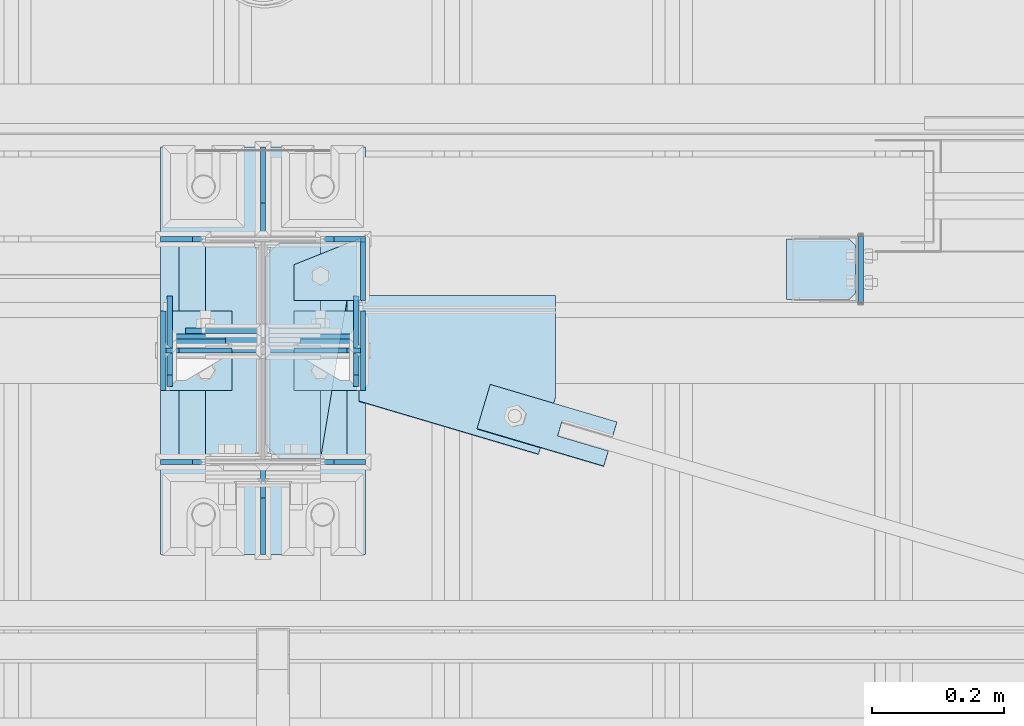
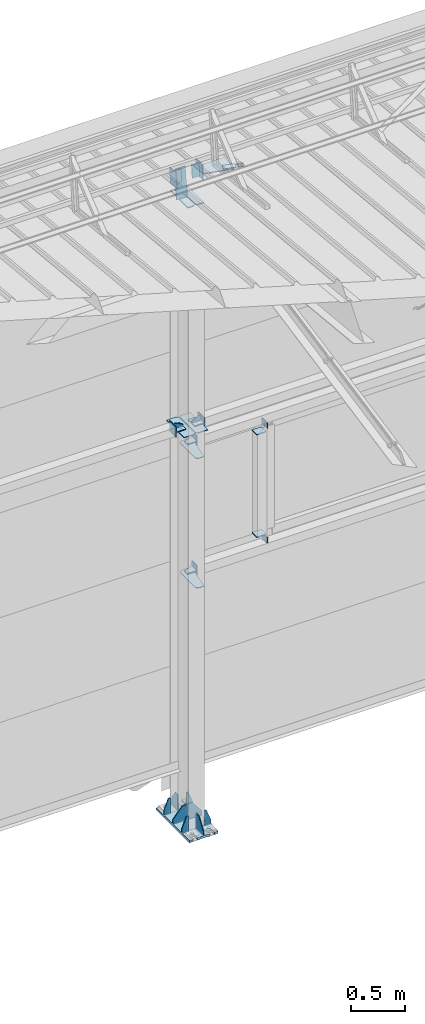
# One storey, part 163 of 709: 36 plates, 5 openings, 9 elements without a shape of their own.
"""IFC4 building model written with IfcOpenShell, lengths in millimetres."""

import ifcopenshell
import ifcopenshell.guid

model = None  # the IFC model being written
_history = None  # IfcOwnerHistory: only IFC2X3 demands one
_inside = {}  # id of a spatial element -> (the spatial element, [elements in it])
_under = {}  # id of a project, library or spatial element -> (it, [spatial elements below it])
_declared = {}  # id of a project -> (the project, [libraries it declares])
_typed = {}  # id of a type object -> (the type object, [elements of that type])
_made_of = {}  # id of a material, layer set ... -> (it, [elements and type objects made of it])


def new_model(schema):
    """Start an empty IFC model of exactly this schema.

    Asked for "IFC4X3", IfcOpenShell would pick the latest addendum, in which some entities
    have other attributes; the version numbers below select the first issue.
    IFC2X3 requires an IfcOwnerHistory on every rooted entity: one is made here for all.
    """
    global model, _history
    if schema == "IFC4X3":
        model = ifcopenshell.file(schema_version=(4, 3, 0, 0))
    else:
        model = ifcopenshell.file(schema=schema)
    _inside.clear()
    _under.clear()
    _declared.clear()
    _typed.clear()
    _made_of.clear()
    _history = None
    if model.schema == "IFC2X3":
        org = make("IfcOrganization", Name="unknown")
        user = make(
            "IfcPersonAndOrganization",
            ThePerson=make("IfcPerson", FamilyName="unknown"),
            TheOrganization=org,
        )
        app = make(
            "IfcApplication",
            ApplicationDeveloper=org,
            Version="unknown",
            ApplicationFullName="unknown",
            ApplicationIdentifier="unknown",
        )
        _history = make(
            "IfcOwnerHistory",
            OwningUser=user,
            OwningApplication=app,
            ChangeAction="ADDED",
            CreationDate=0,
        )
    return model


def make(cls, **values):
    """One entity of the class cls with the attributes given. An attribute that is None is left unset."""
    return model.create_entity(
        cls, **{name: value for name, value in values.items() if value is not None}
    )


def rooted(cls, **values):
    """An entity with a GlobalId (a new one), such as an element, a storey or a relation."""
    return make(cls, GlobalId=ifcopenshell.guid.new(), OwnerHistory=_history, **values)


def si_unit(unit_type, name, prefix=None):
    """IfcSIUnit, for example si_unit("LENGTHUNIT", "METRE", prefix="MILLI")."""
    return make("IfcSIUnit", UnitType=unit_type, Prefix=prefix, Name=name)


def assignment(units):
    """IfcUnitAssignment: the units of a project."""
    return None if units is None else make("IfcUnitAssignment", Units=units)


def point(xyz):
    """IfcCartesianPoint."""
    return None if xyz is None else make("IfcCartesianPoint", Coordinates=xyz)


def direction(xyz):
    """IfcDirection."""
    return None if xyz is None else make("IfcDirection", DirectionRatios=xyz)


def frame(location, z_axis=None, x_axis=None):
    """IfcAxis2Placement3D, a coordinate frame: its origin and axes. An axis left out is left unset."""
    return make(
        "IfcAxis2Placement3D",
        Location=point(location),
        Axis=direction(z_axis),
        RefDirection=direction(x_axis),
    )


def origin_with_axes():
    """The frame at (0, 0, 0) with the z axis (0, 0, 1) and the x axis (1, 0, 0) written out."""
    return frame((0.0, 0.0, 0.0), z_axis=(0.0, 0.0, 1.0), x_axis=(1.0, 0.0, 0.0))


def place(relative_to, where):
    """IfcLocalPlacement: puts the frame where relative to a parent placement (None: the world)."""
    return make(
        "IfcLocalPlacement", PlacementRelTo=relative_to, RelativePlacement=where
    )


def context(
    kind, dimensions, precision=None, world=None, true_north=None, identifier=None
):
    """IfcGeometricRepresentationContext, for example the 3D "Model" context."""
    return make(
        "IfcGeometricRepresentationContext",
        ContextIdentifier=identifier,
        ContextType=kind,
        CoordinateSpaceDimension=dimensions,
        Precision=precision,
        WorldCoordinateSystem=world,
        TrueNorth=true_north,
    )


def subcontext(parent, identifier, kind, view, scale=None):
    """IfcGeometricRepresentationSubContext, for example "Body" below "Model"."""
    return make(
        "IfcGeometricRepresentationSubContext",
        ContextIdentifier=identifier,
        ContextType=kind,
        ParentContext=parent,
        TargetScale=scale,
        TargetView=view,
    )


def project(units=None, contexts=None):
    """IfcProject with its units and contexts."""
    return rooted(
        "IfcProject",
        Name="project",
        RepresentationContexts=contexts,
        UnitsInContext=assignment(units),
    )


def spatial(cls, under=None, at=None, **own):
    """A site, building, storey or space (cls), placed at a placement, below another one or the project."""
    s = rooted(cls, ObjectPlacement=at, **own)
    if under is not None:
        _under.setdefault(under.id(), (under, []))[1].append(s)
    return s


def point_list(points):
    """IfcCartesianPointList2D or 3D."""
    cls = (
        "IfcCartesianPointList2D" if len(points[0]) == 2 else "IfcCartesianPointList3D"
    )
    return make(cls, CoordList=points)


def line(*indices):
    """IfcLineIndex: a straight run through numbered points of an indexed curve."""
    return model.create_entity("IfcLineIndex", indices)


def arc(*indices):
    """IfcArcIndex: an arc through three numbered points of an indexed curve."""
    return model.create_entity("IfcArcIndex", indices)


def indexed_curve(points, segments=None, self_intersect=None):
    """IfcIndexedPolyCurve: lines and arcs through numbered points (the first is 1)."""
    return make(
        "IfcIndexedPolyCurve",
        Points=point_list(points),
        Segments=segments,
        SelfIntersect=self_intersect,
    )


def outline(outer, holes=None, kind="AREA"):
    """IfcArbitraryClosedProfileDef: a profile drawn as a closed curve; with holes, ...WithVoids."""
    if holes is None:
        return make("IfcArbitraryClosedProfileDef", ProfileType=kind, OuterCurve=outer)
    return make(
        "IfcArbitraryProfileDefWithVoids",
        ProfileType=kind,
        OuterCurve=outer,
        InnerCurves=holes,
    )


def extrude(swept, where, along, depth):
    """IfcExtrudedAreaSolid: the profile swept, set in the frame where, extruded along a direction by depth."""
    return make(
        "IfcExtrudedAreaSolid",
        SweptArea=swept,
        Position=where,
        ExtrudedDirection=direction(along),
        Depth=depth,
    )


def shape(context_of_items, identifier, shape_type, items):
    """IfcShapeRepresentation: the items that make up one representation, for example the "Body"."""
    return make(
        "IfcShapeRepresentation",
        ContextOfItems=context_of_items,
        RepresentationIdentifier=identifier,
        RepresentationType=shape_type,
        Items=items,
    )


def material(Name=None, Category=None):
    """IfcMaterial."""
    return make("IfcMaterial", Name=Name, Category=Category)


def made_of(thing, what):
    """Note that an element or type object is made of a material, layer set ...; save() writes the relation."""
    if what is not None:
        _made_of.setdefault(what.id(), (what, []))[1].append(thing)
    return thing


def element(
    cls,
    number,
    at=None,
    inside=None,
    cuts=None,
    type_object=None,
    material=None,
    context=None,
    identifier="Body",
    shape_type=None,
    held_by="IfcProductDefinitionShape",
    body=None,
    shapes=None,
    **own,
):
    """One element of the class cls, such as IfcWall. Its Tag is "e" and its number.

    at: its placement. inside: the storey or other place that contains it. cuts: it is an
    opening in that element (IfcRelVoidsElement). A single representation is given by context,
    identifier, shape_type and body (its items); several are given by shapes. held_by: the class
    of the entity that holds the representations. save() writes the other relations.
    """
    e = rooted(cls, Tag="e%d" % number, ObjectPlacement=at, **own)
    if body is not None:
        shapes = [shape(context, identifier, shape_type, body)]
    if shapes is not None:
        e.Representation = make(held_by, Representations=shapes)
    if inside is not None:
        _inside.setdefault(inside.id(), (inside, []))[1].append(e)
    if cuts is not None:
        rooted(
            "IfcRelVoidsElement", RelatingBuildingElement=cuts, RelatedOpeningElement=e
        )
    if type_object is not None:
        _typed.setdefault(type_object.id(), (type_object, []))[1].append(e)
    return made_of(e, material)


def aggregate(whole, parts):
    """IfcRelAggregates: a whole, such as a stair, and the parts it consists of."""
    return rooted("IfcRelAggregates", RelatingObject=whole, RelatedObjects=parts)


def save(model, path):
    """Write the relations noted so far, then the file.

    IfcRelAggregates (storeys below a building ...), IfcRelContainedInSpatialStructure (elements
    in a storey), IfcRelDefinesByType, IfcRelAssociatesMaterial and IfcRelDeclares: one each for
    every whole, place, type object, material and project.
    """
    for whole, parts in _under.values():
        aggregate(whole, parts)
    for where, things in _inside.values():
        rooted(
            "IfcRelContainedInSpatialStructure",
            RelatedElements=things,
            RelatingStructure=where,
        )
    for kind, things in _typed.values():
        rooted("IfcRelDefinesByType", RelatedObjects=things, RelatingType=kind)
    for what, things in _made_of.values():
        rooted("IfcRelAssociatesMaterial", RelatedObjects=things, RelatingMaterial=what)
    for by, libraries in _declared.values():
        rooted("IfcRelDeclares", RelatingContext=by, RelatedDefinitions=libraries)
    model.write(path)


model = new_model("IFC4")

# Units and contexts
model_context = context("Model", 3, precision=0.2, world=origin_with_axes(), true_north=direction((0.0, 1.0)))
body_context = subcontext(model_context, "Body", "Model", "MODEL_VIEW")
ifc_project = project(units=[si_unit("LENGTHUNIT", "METRE", prefix="MILLI"), si_unit("AREAUNIT", "SQUARE_METRE"), si_unit("VOLUMEUNIT", "CUBIC_METRE"), si_unit("MASSUNIT", "GRAM", prefix="KILO"), si_unit("TIMEUNIT", "SECOND"), si_unit("PLANEANGLEUNIT", "RADIAN"), si_unit("SOLIDANGLEUNIT", "STERADIAN"), si_unit("THERMODYNAMICTEMPERATUREUNIT", "DEGREE_CELSIUS"), si_unit("LUMINOUSINTENSITYUNIT", "LUMEN")], contexts=[model_context])

# Site, building, storey
site_placement = place(None, origin_with_axes())
site = spatial("IfcSite", under=ifc_project, at=site_placement, CompositionType="ELEMENT")
building_placement = place(site_placement, origin_with_axes())
building = spatial("IfcBuilding", under=site, at=building_placement, Name="Undefined", CompositionType="ELEMENT")
storey_placement = place(building_placement, origin_with_axes())
storey = spatial("IfcBuildingStorey", under=building, at=storey_placement, Name="Undefined", CompositionType="ELEMENT", Elevation=0.0)

# Assembly, plates, voiding features
assembly_1_placement = place(storey_placement, frame((40000.0, 21827.0, -200.0), z_axis=(-1.0, 0.0, 0.0), x_axis=(0.0, 0.0, 1.0)))
assembly_1 = element("IfcElementAssembly", 1, at=assembly_1_placement, inside=storey)
ifc_material = material(Name="C355-6", Category="STEEL")
plate_1_placement = place(assembly_1_placement, frame((7434.21546, 30.02526, 3.0), z_axis=(0.099503719, -0.9950371902, 0.0), x_axis=(0.0, 0.0, 1.0)))
plate_1 = element("IfcPlate", 2, at=plate_1_placement, material=ifc_material, ObjectType="595", context=body_context, shape_type="SolidModel", body=[
    extrude(outline(indexed_curve([(0.0, 0.0), (114.0, 0.0), (114.0, 332.53554), (0.0, 332.53554)], segments=[line(1, 2, 3, 4, 1)])), frame((0.0, 0.0, 4.0), z_axis=(0.0, 0.0, 1.0), x_axis=(1.0, 0.0, 0.0)), (0.0, 0.0, -1.0), 8.0),
])
plate_2_placement = place(assembly_1_placement, frame((4502.0, 163.0, 127.0), z_axis=(-1.0, 0.0, 0.0), x_axis=(0.0, 0.0, -1.0)))
plate_2 = element("IfcPlate", 3, at=plate_2_placement, material=ifc_material, ObjectType="547", context=body_context, shape_type="SolidModel", body=[
    extrude(outline(indexed_curve([(0.0, 0.0), (108.0, 0.0), (123.0, 15.0), (123.0, 311.0), (108.0, 326.0), (0.0, 326.0)], segments=[line(1, 2, 3, 4, 5, 6, 1)])), frame((0.0, 0.0, 4.0), z_axis=(0.0, 0.0, 1.0), x_axis=(1.0, 0.0, 0.0)), (0.0, 0.0, -1.0), 8.0),
])
plate_3_placement = place(assembly_1_placement, frame((4502.0, -163.0, -127.0), z_axis=(-1.0, 0.0, 0.0), x_axis=(0.0, 0.0, 1.0)))
plate_3 = element("IfcPlate", 4, at=plate_3_placement, material=ifc_material, ObjectType="547", context=body_context, shape_type="SolidModel", body=[
    extrude(outline(indexed_curve([(0.0, 0.0), (108.0, 0.0), (123.0, 15.0), (123.0, 311.0), (108.0, 326.0), (0.0, 326.0)], segments=[line(1, 2, 3, 4, 5, 6, 1)])), frame((0.0, 0.0, 4.0), z_axis=(0.0, 0.0, 1.0), x_axis=(1.0, 0.0, 0.0)), (0.0, 0.0, -1.0), 8.0),
])
plate_4_placement = place(assembly_1_placement, frame((4212.0, -163.0, -4.0), z_axis=(1.0, 0.0, 0.0), x_axis=(0.0, 0.0, -1.0)))
plate_4 = element("IfcPlate", 5, at=plate_4_placement, material=ifc_material, ObjectType="543", context=body_context, shape_type="SolidModel", body=[
    extrude(outline(indexed_curve([(0.0, 20.0), (20.0, 0.0), (83.0, 0.0), (123.0, 240.0), (123.0, 326.0), (20.0, 326.0), (0.0, 306.0)], segments=[line(1, 2, 3, 4, 5, 6, 7, 1)])), frame((0.0, 0.0, 4.0), z_axis=(0.0, 0.0, 1.0), x_axis=(1.0, 0.0, 0.0)), (0.0, 0.0, -1.0), 8.0),
])
plate_5_placement = place(assembly_1_placement, frame((2742.0, -163.0, -4.0), z_axis=(1.0, 0.0, 0.0), x_axis=(0.0, 0.0, -1.0)))
plate_5 = element("IfcPlate", 6, at=plate_5_placement, material=ifc_material, ObjectType="543", context=body_context, shape_type="SolidModel", body=[
    extrude(outline(indexed_curve([(0.0, 20.0), (20.0, 0.0), (83.0, 0.0), (123.0, 240.0), (123.0, 326.0), (20.0, 326.0), (0.0, 306.0)], segments=[line(1, 2, 3, 4, 5, 6, 7, 1)])), frame((0.0, 0.0, 4.0), z_axis=(0.0, 0.0, 1.0), x_axis=(1.0, 0.0, 0.0)), (0.0, 0.0, -1.0), 8.0),
])
plate_6_placement = place(assembly_1_placement, frame((7097.93718, 163.0, 87.0), z_axis=(-1.0, 0.0, 0.0), x_axis=(0.0, 0.0, -1.0)))
plate_6 = element("IfcPlate", 7, at=plate_6_placement, material=ifc_material, ObjectType="461", context=body_context, shape_type="SolidModel", body=[
    extrude(outline(indexed_curve([(0.0, 0.0), (68.0, 0.0), (83.0, 15.0), (83.0, 311.0), (68.0, 326.0), (0.0, 326.0)], segments=[line(1, 2, 3, 4, 5, 6, 1)])), frame((0.0, 0.0, 4.0), z_axis=(0.0, 0.0, 1.0), x_axis=(1.0, 0.0, 0.0)), (0.0, 0.0, -1.0), 8.0),
])
plate_7_placement = place(assembly_1_placement, frame((7097.93718, -163.0, -87.0), z_axis=(-1.0, 0.0, 0.0), x_axis=(0.0, 0.0, 1.0)))
plate_7 = element("IfcPlate", 8, at=plate_7_placement, material=ifc_material, ObjectType="461", context=body_context, shape_type="SolidModel", body=[
    extrude(outline(indexed_curve([(0.0, 0.0), (68.0, 0.0), (83.0, 15.0), (83.0, 311.0), (68.0, 326.0), (0.0, 326.0)], segments=[line(1, 2, 3, 4, 5, 6, 1)])), frame((0.0, 0.0, 4.0), z_axis=(0.0, 0.0, 1.0), x_axis=(1.0, 0.0, 0.0)), (0.0, 0.0, -1.0), 8.0),
])
plate_8_placement = place(assembly_1_placement, frame((25.0, 173.0, 0.0), z_axis=(0.0, 0.0, -1.0), x_axis=(0.0, 1.0, 0.0)))
plate_8 = element("IfcPlate", 9, at=plate_8_placement, material=ifc_material, ObjectType="418", context=body_context, shape_type="SolidModel", body=[
    extrude(outline(indexed_curve([(0.0, 0.0), (135.0, 0.0), (135.0, 50.0), (50.0, 175.0), (0.0, 175.0)], segments=[line(1, 2, 3, 4, 5, 1)])), frame((0.0, 0.0, 4.0), z_axis=(0.0, 0.0, 1.0), x_axis=(1.0, 0.0, 0.0)), (0.0, 0.0, -1.0), 8.0),
])
plate_9_placement = place(assembly_1_placement, frame((25.0, 0.0, 3.0), z_axis=(0.0, 1.0, 0.0), x_axis=(0.0, 0.0, 1.0)))
plate_9 = element("IfcPlate", 10, at=plate_9_placement, material=ifc_material, ObjectType="417", context=body_context, shape_type="SolidModel", body=[
    extrude(outline(indexed_curve([(0.0, 0.0), (152.0, 0.0), (152.0, 50.0), (50.0, 175.0), (0.0, 175.0)], segments=[line(1, 2, 3, 4, 5, 1)])), frame((0.0, 0.0, 4.0), z_axis=(0.0, 0.0, 1.0), x_axis=(1.0, 0.0, 0.0)), (0.0, 0.0, -1.0), 8.0),
])
plate_10_placement = place(assembly_1_placement, frame((25.0, -168.5, 87.0), z_axis=(0.0, 1.0, 0.0), x_axis=(0.0, 0.0, 1.0)))
plate_10 = element("IfcPlate", 11, at=plate_10_placement, material=ifc_material, ObjectType="419", context=body_context, shape_type="SolidModel", body=[
    extrude(outline(indexed_curve([(0.0, 0.0), (68.0, 0.0), (68.0, 50.0), (20.0, 175.0), (0.0, 175.0)], segments=[line(1, 2, 3, 4, 5, 1)])), frame((0.0, 0.0, 4.0), z_axis=(0.0, 0.0, 1.0), x_axis=(1.0, 0.0, 0.0)), (0.0, 0.0, -1.0), 8.0),
])
plate_11_placement = place(assembly_1_placement, frame((25.0, 168.5, -87.0), z_axis=(0.0, -1.0, 0.0), x_axis=(0.0, 0.0, -1.0)))
plate_11 = element("IfcPlate", 12, at=plate_11_placement, material=ifc_material, ObjectType="419", context=body_context, shape_type="SolidModel", body=[
    extrude(outline(indexed_curve([(0.0, 0.0), (68.0, 0.0), (68.0, 50.0), (20.0, 175.0), (0.0, 175.0)], segments=[line(1, 2, 3, 4, 5, 1)])), frame((0.0, 0.0, 4.0), z_axis=(0.0, 0.0, 1.0), x_axis=(1.0, 0.0, 0.0)), (0.0, 0.0, -1.0), 8.0),
])
plate_12_placement = place(assembly_1_placement, frame((25.0, 168.5, 87.0), z_axis=(0.0, 1.0, 0.0), x_axis=(0.0, 0.0, 1.0)))
plate_12 = element("IfcPlate", 13, at=plate_12_placement, material=ifc_material, ObjectType="419", context=body_context, shape_type="SolidModel", body=[
    extrude(outline(indexed_curve([(0.0, 0.0), (68.0, 0.0), (68.0, 50.0), (20.0, 175.0), (0.0, 175.0)], segments=[line(1, 2, 3, 4, 5, 1)])), frame((0.0, 0.0, 4.0), z_axis=(0.0, 0.0, 1.0), x_axis=(1.0, 0.0, 0.0)), (0.0, 0.0, -1.0), 8.0),
])
plate_13_placement = place(assembly_1_placement, frame((25.0, 0.0, -3.0), z_axis=(0.0, -1.0, 0.0), x_axis=(0.0, 0.0, -1.0)))
plate_13 = element("IfcPlate", 14, at=plate_13_placement, material=ifc_material, ObjectType="417", context=body_context, shape_type="SolidModel", body=[
    extrude(outline(indexed_curve([(0.0, 0.0), (152.0, 0.0), (152.0, 50.0), (50.0, 175.0), (0.0, 175.0)], segments=[line(1, 2, 3, 4, 5, 1)])), frame((0.0, 0.0, 4.0), z_axis=(0.0, 0.0, 1.0), x_axis=(1.0, 0.0, 0.0)), (0.0, 0.0, -1.0), 8.0),
])
plate_14_placement = place(assembly_1_placement, frame((25.0, -173.0, 0.0), z_axis=(0.0, 0.0, 1.0), x_axis=(0.0, -1.0, 0.0)))
plate_14 = element("IfcPlate", 15, at=plate_14_placement, material=ifc_material, ObjectType="418", context=body_context, shape_type="SolidModel", body=[
    extrude(outline(indexed_curve([(0.0, 0.0), (135.0, 0.0), (135.0, 50.0), (50.0, 175.0), (0.0, 175.0)], segments=[line(1, 2, 3, 4, 5, 1)])), frame((0.0, 0.0, 4.0), z_axis=(0.0, 0.0, 1.0), x_axis=(1.0, 0.0, 0.0)), (0.0, 0.0, -1.0), 8.0),
])
plate_15_placement = place(assembly_1_placement, frame((25.0, -168.5, -87.0), z_axis=(0.0, -1.0, 0.0), x_axis=(0.0, 0.0, -1.0)))
plate_15 = element("IfcPlate", 16, at=plate_15_placement, material=ifc_material, ObjectType="419", context=body_context, shape_type="SolidModel", body=[
    extrude(outline(indexed_curve([(0.0, 0.0), (68.0, 0.0), (68.0, 50.0), (20.0, 175.0), (0.0, 175.0)], segments=[line(1, 2, 3, 4, 5, 1)])), frame((0.0, 0.0, 4.0), z_axis=(0.0, 0.0, 1.0), x_axis=(1.0, 0.0, 0.0)), (0.0, 0.0, -1.0), 8.0),
])
plate_16_placement = place(assembly_1_placement, frame((12.5, -308.0, 155.0), z_axis=(1.0, 0.0, 0.0), x_axis=(0.0, 0.0, -1.0)))
plate_16 = element("IfcPlate", 17, at=plate_16_placement, material=ifc_material, ObjectType="416", context=body_context, shape_type="SolidModel", body=[
    extrude(outline(indexed_curve([(0.0, 0.0), (310.0, 0.0), (310.0, 616.0), (0.0, 616.0)], segments=[line(1, 2, 3, 4, 1)])), frame((0.0, 0.0, 12.5), z_axis=(0.0, 0.0, 1.0), x_axis=(1.0, 0.0, 0.0)), (0.0, 0.0, -1.0), 25.0),
])
voiding_feature_1_placement = place(plate_16_placement, frame((40.0, 616.0, 0.0), z_axis=(0.0, 0.0, -1.0), x_axis=(1.0, 0.0, 0.0)))
element("IfcVoidingFeature", 18, at=voiding_feature_1_placement, cuts=plate_16, PredefinedType="HOLE", context=body_context, shape_type="SolidModel", body=[
    extrude(outline(indexed_curve([(0.0, 0.0), (50.0, 0.0), (50.0, 60.0), (42.67767, 77.67767), (25.0, 85.0), (25.0, 85.0), (7.32233, 77.67767), (0.0, 60.0)], segments=[line(1, 2, 3), arc(3, 4, 5), line(5, 6), arc(6, 7, 8), line(8, 1)])), frame((0.0, 0.0, 12.5), z_axis=(0.0, 0.0, 1.0), x_axis=(1.0, 0.0, 0.0)), (0.0, 0.0, -1.0), 25.0),
])
voiding_feature_2_placement = place(plate_16_placement, frame((40.0, 0.0, 0.0), z_axis=(0.0, 0.0, 1.0), x_axis=(1.0, 0.0, 0.0)))
element("IfcVoidingFeature", 19, at=voiding_feature_2_placement, cuts=plate_16, PredefinedType="HOLE", context=body_context, shape_type="SolidModel", body=[
    extrude(outline(indexed_curve([(0.0, 0.0), (50.0, 0.0), (50.0, 60.0), (42.67767, 77.67767), (25.0, 85.0), (25.0, 85.0), (7.32233, 77.67767), (0.0, 60.0)], segments=[line(1, 2, 3), arc(3, 4, 5), line(5, 6), arc(6, 7, 8), line(8, 1)])), frame((0.0, 0.0, 12.5), z_axis=(0.0, 0.0, 1.0), x_axis=(1.0, 0.0, 0.0)), (0.0, 0.0, -1.0), 25.0),
])
voiding_feature_3_placement = place(plate_16_placement, frame((270.0, 616.0, 0.0), z_axis=(0.0, 0.0, 1.0), x_axis=(-1.0, 0.0, 0.0)))
element("IfcVoidingFeature", 20, at=voiding_feature_3_placement, cuts=plate_16, PredefinedType="HOLE", context=body_context, shape_type="SolidModel", body=[
    extrude(outline(indexed_curve([(0.0, 0.0), (50.0, 0.0), (50.0, 60.0), (42.67767, 77.67767), (25.0, 85.0), (25.0, 85.0), (7.32233, 77.67767), (0.0, 60.0)], segments=[line(1, 2, 3), arc(3, 4, 5), line(5, 6), arc(6, 7, 8), line(8, 1)])), frame((0.0, 0.0, 12.5), z_axis=(0.0, 0.0, 1.0), x_axis=(1.0, 0.0, 0.0)), (0.0, 0.0, -1.0), 25.0),
])
voiding_feature_4_placement = place(plate_16_placement, frame((270.0, 0.0, 0.0), z_axis=(0.0, 0.0, -1.0), x_axis=(-1.0, 0.0, 0.0)))
element("IfcVoidingFeature", 21, at=voiding_feature_4_placement, cuts=plate_16, PredefinedType="HOLE", context=body_context, shape_type="SolidModel", body=[
    extrude(outline(indexed_curve([(0.0, 0.0), (50.0, 0.0), (50.0, 60.0), (42.67767, 77.67767), (25.0, 85.0), (25.0, 85.0), (7.32233, 77.67767), (0.0, 60.0)], segments=[line(1, 2, 3), arc(3, 4, 5), line(5, 6), arc(6, 7, 8), line(8, 1)])), frame((0.0, 0.0, 12.5), z_axis=(0.0, 0.0, 1.0), x_axis=(1.0, 0.0, 0.0)), (0.0, 0.0, -1.0), 25.0),
])
aggregate(assembly_1, [plate_1, plate_2, plate_3, plate_4, plate_5, plate_6, plate_7, plate_8, plate_9, plate_10, plate_11, plate_12, plate_13, plate_14, plate_15, plate_16])

# Assembly, plates
assembly_2_placement = place(storey_placement, frame((46000.0, 21950.0, 2550.0), z_axis=(0.0, 0.0, -1.0), x_axis=(-1.0, 0.0, 0.0)))
assembly_2 = element("IfcElementAssembly", 22, at=assembly_2_placement, inside=storey)
plate_17_placement = place(assembly_2_placement, frame((5096.0, 50.0, -50.0), z_axis=(-1.0, 0.0, 0.0), x_axis=(0.0, 0.0, -1.0)))
plate_17 = element("IfcPlate", 23, at=plate_17_placement, material=ifc_material, ObjectType="509", context=body_context, shape_type="SolidModel", body=[
    extrude(outline(indexed_curve([(0.0, 0.0), (65.0, 0.0), (65.0, 100.0), (0.0, 100.0)], segments=[line(1, 2, 3, 4, 1)])), frame((0.0, 0.0, 4.0), z_axis=(0.0, 0.0, 1.0), x_axis=(1.0, 0.0, 0.0)), (0.0, 0.0, -1.0), 8.0),
])
plate_18_placement = place(assembly_2_placement, frame((5853.0, 47.0, 0.0), z_axis=(0.0, 0.0, 1.0), x_axis=(0.0, -1.0, 0.0)))
plate_18 = element("IfcPlate", 24, at=plate_18_placement, material=ifc_material, ObjectType="502", context=body_context, shape_type="SolidModel", body=[
    extrude(outline(indexed_curve([(0.0, 0.0), (94.0, 0.0), (94.0, 100.0), (40.0, 100.0), (0.0, 0.0)], segments=[line(1, 2, 3, 4, 5, 1)])), frame((0.0, 0.0, 4.0), z_axis=(0.0, 0.0, 1.0), x_axis=(1.0, 0.0, 0.0)), (0.0, 0.0, -1.0), 8.0),
])
plate_19_placement = place(assembly_2_placement, frame((5849.0, 47.0, -60.0), z_axis=(-1.0, 0.0, 0.0), x_axis=(0.0, -1.0, 0.0)))
plate_19 = element("IfcPlate", 25, at=plate_19_placement, material=ifc_material, ObjectType="501", context=body_context, shape_type="SolidModel", body=[
    extrude(outline(indexed_curve([(0.0, 0.0), (94.0, 0.0), (94.0, 120.0), (0.0, 120.0)], segments=[line(1, 2, 3, 4, 1)])), frame((0.0, 0.0, 4.0), z_axis=(0.0, 0.0, 1.0), x_axis=(1.0, 0.0, 0.0)), (0.0, 0.0, -1.0), 8.0),
])
aggregate(assembly_2, [plate_17, plate_18, plate_19])

assembly_3_placement = place(storey_placement, frame((46000.0, 21950.0, 4020.0), z_axis=(0.0, 0.0, -1.0), x_axis=(-1.0, 0.0, 0.0)))
assembly_3 = element("IfcElementAssembly", 26, at=assembly_3_placement, inside=storey)
plate_20_placement = place(assembly_3_placement, frame((5096.0, -50.0, 50.0), z_axis=(-1.0, 0.0, 0.0), x_axis=(0.0, 0.0, 1.0)))
plate_20 = element("IfcPlate", 27, at=plate_20_placement, material=ifc_material, ObjectType="509", context=body_context, shape_type="SolidModel", body=[
    extrude(outline(indexed_curve([(0.0, 0.0), (65.0, 0.0), (65.0, 100.0), (0.0, 100.0)], segments=[line(1, 2, 3, 4, 1)])), frame((0.0, 0.0, 4.0), z_axis=(0.0, 0.0, 1.0), x_axis=(1.0, 0.0, 0.0)), (0.0, 0.0, -1.0), 8.0),
])
plate_21_placement = place(assembly_3_placement, frame((5853.0, 47.0, 0.0), z_axis=(0.0, 0.0, 1.0), x_axis=(0.0, -1.0, 0.0)))
plate_21 = element("IfcPlate", 28, at=plate_21_placement, material=ifc_material, ObjectType="502", context=body_context, shape_type="SolidModel", body=[
    extrude(outline(indexed_curve([(0.0, 0.0), (94.0, 0.0), (94.0, 100.0), (40.0, 100.0), (0.0, 0.0)], segments=[line(1, 2, 3, 4, 5, 1)])), frame((0.0, 0.0, 4.0), z_axis=(0.0, 0.0, 1.0), x_axis=(1.0, 0.0, 0.0)), (0.0, 0.0, -1.0), 8.0),
])
plate_22_placement = place(assembly_3_placement, frame((5849.0, 47.0, -60.0), z_axis=(-1.0, 0.0, 0.0), x_axis=(0.0, -1.0, 0.0)))
plate_22 = element("IfcPlate", 29, at=plate_22_placement, material=ifc_material, ObjectType="501", context=body_context, shape_type="SolidModel", body=[
    extrude(outline(indexed_curve([(0.0, 0.0), (94.0, 0.0), (94.0, 120.0), (0.0, 120.0)], segments=[line(1, 2, 3, 4, 1)])), frame((0.0, 0.0, 4.0), z_axis=(0.0, 0.0, 1.0), x_axis=(1.0, 0.0, 0.0)), (0.0, 0.0, -1.0), 8.0),
])
aggregate(assembly_3, [plate_20, plate_21, plate_22])

assembly_4_placement = place(storey_placement, frame((40850.0, 21950.0, 2600.0), z_axis=(-1.0, 0.0, 0.0), x_axis=(0.0, 0.0, 1.0)))
assembly_4 = element("IfcElementAssembly", 30, at=assembly_4_placement, inside=storey)
plate_23_placement = place(assembly_4_placement, frame((103.0, 46.0, -46.0), z_axis=(-1.0, 0.0, 0.0), x_axis=(0.0, -1.0, 0.0)))
plate_23 = element("IfcPlate", 31, at=plate_23_placement, material=ifc_material, ObjectType="510", context=body_context, shape_type="SolidModel", body=[
    extrude(outline(indexed_curve([(0.0, 10.0), (10.0, 0.0), (82.0, 0.0), (92.0, 10.0), (92.0, 104.0), (0.0, 104.0)], segments=[line(1, 2, 3, 4, 5, 6, 1)])), frame((0.0, 0.0, 4.0), z_axis=(0.0, 0.0, 1.0), x_axis=(1.0, 0.0, 0.0)), (0.0, 0.0, -1.0), 8.0),
])
plate_24_placement = place(assembly_4_placement, frame((1267.0, -46.0, -46.0), z_axis=(1.0, 0.0, 0.0), x_axis=(0.0, 1.0, 0.0)))
plate_24 = element("IfcPlate", 32, at=plate_24_placement, material=ifc_material, ObjectType="510", context=body_context, shape_type="SolidModel", body=[
    extrude(outline(indexed_curve([(0.0, 10.0), (10.0, 0.0), (82.0, 0.0), (92.0, 10.0), (92.0, 104.0), (0.0, 104.0)], segments=[line(1, 2, 3, 4, 5, 6, 1)])), frame((0.0, 0.0, 4.0), z_axis=(0.0, 0.0, 1.0), x_axis=(1.0, 0.0, 0.0)), (0.0, 0.0, -1.0), 8.0),
])
aggregate(assembly_4, [plate_23, plate_24])

assembly_5_placement = place(storey_placement, frame((46000.0, 21827.0, 4310.0), z_axis=(0.0, 0.0, -1.0), x_axis=(-1.0, 0.0, 0.0)))
assembly_5 = element("IfcElementAssembly", 33, at=assembly_5_placement, inside=storey)
plate_25_placement = place(assembly_5_placement, frame((5953.0, 0.0, -60.0), z_axis=(0.0, -1.0, 0.0), x_axis=(0.0, 0.0, 1.0)))
plate_25 = element("IfcPlate", 34, at=plate_25_placement, material=ifc_material, ObjectType="508", context=body_context, shape_type="SolidModel", body=[
    extrude(outline(indexed_curve([(0.0, 80.0), (36.0, 0.0), (56.0, 0.0), (56.0, 90.0), (46.0, 100.0), (0.0, 100.0)], segments=[line(1, 2, 3, 4, 5, 6, 1)])), frame((0.0, 0.0, 4.0), z_axis=(0.0, 0.0, 1.0), x_axis=(1.0, 0.0, 0.0)), (0.0, 0.0, -1.0), 8.0),
])
plate_26_placement = place(assembly_5_placement, frame((5953.0, -60.0, 0.0), z_axis=(0.0, 0.0, 1.0), x_axis=(0.0, 1.0, 0.0)))
plate_26 = element("IfcPlate", 35, at=plate_26_placement, material=ifc_material, ObjectType="507", context=body_context, shape_type="SolidModel", body=[
    extrude(outline(indexed_curve([(0.0, 0.0), (120.0, 0.0), (120.0, 100.0), (0.0, 100.0)], segments=[line(1, 2, 3, 4, 1)])), frame((0.0, 0.0, 4.0), z_axis=(0.0, 0.0, 1.0), x_axis=(1.0, 0.0, 0.0)), (0.0, 0.0, -1.0), 8.0),
])
plate_27_placement = place(assembly_5_placement, frame((5849.0, -60.0, 60.0), z_axis=(1.0, 0.0, 0.0), x_axis=(0.0, 0.0, -1.0)))
plate_27 = element("IfcPlate", 36, at=plate_27_placement, material=ifc_material, ObjectType="506", context=body_context, shape_type="SolidModel", body=[
    extrude(outline(indexed_curve([(0.0, 0.0), (120.0, 0.0), (120.0, 120.0), (0.0, 120.0)], segments=[line(1, 2, 3, 4, 1)])), frame((0.0, 0.0, 4.0), z_axis=(0.0, 0.0, 1.0), x_axis=(1.0, 0.0, 0.0)), (0.0, 0.0, -1.0), 8.0),
])
aggregate(assembly_5, [plate_25, plate_26, plate_27])

assembly_6_placement = place(storey_placement, frame((40000.0, 21827.0, 4310.0), z_axis=(0.0, 0.0, -1.0), x_axis=(-1.0, 0.0, 0.0)))
assembly_6 = element("IfcElementAssembly", 37, at=assembly_6_placement, inside=storey)
plate_28_placement = place(assembly_6_placement, frame((151.0, 60.0, 60.0), z_axis=(-1.0, 0.0, 0.0), x_axis=(0.0, 0.0, -1.0)))
plate_28 = element("IfcPlate", 38, at=plate_28_placement, material=ifc_material, ObjectType="506", context=body_context, shape_type="SolidModel", body=[
    extrude(outline(indexed_curve([(0.0, 0.0), (120.0, 0.0), (120.0, 120.0), (0.0, 120.0)], segments=[line(1, 2, 3, 4, 1)])), frame((0.0, 0.0, 4.0), z_axis=(0.0, 0.0, 1.0), x_axis=(1.0, 0.0, 0.0)), (0.0, 0.0, -1.0), 8.0),
])
plate_29_placement = place(assembly_6_placement, frame((47.0, 0.0, -60.0), z_axis=(0.0, 1.0, 0.0), x_axis=(0.0, 0.0, 1.0)))
plate_29 = element("IfcPlate", 39, at=plate_29_placement, material=ifc_material, ObjectType="508", context=body_context, shape_type="SolidModel", body=[
    extrude(outline(indexed_curve([(0.0, 80.0), (36.0, 0.0), (56.0, 0.0), (56.0, 90.0), (46.0, 100.0), (0.0, 100.0)], segments=[line(1, 2, 3, 4, 5, 6, 1)])), frame((0.0, 0.0, 4.0), z_axis=(0.0, 0.0, 1.0), x_axis=(1.0, 0.0, 0.0)), (0.0, 0.0, -1.0), 8.0),
])
plate_30_placement = place(assembly_6_placement, frame((47.0, 60.0, 0.0), z_axis=(0.0, 0.0, 1.0), x_axis=(0.0, -1.0, 0.0)))
plate_30 = element("IfcPlate", 40, at=plate_30_placement, material=ifc_material, ObjectType="507", context=body_context, shape_type="SolidModel", body=[
    extrude(outline(indexed_curve([(0.0, 0.0), (120.0, 0.0), (120.0, 100.0), (0.0, 100.0)], segments=[line(1, 2, 3, 4, 1)])), frame((0.0, 0.0, 4.0), z_axis=(0.0, 0.0, 1.0), x_axis=(1.0, 0.0, 0.0)), (0.0, 0.0, -1.0), 8.0),
])
aggregate(assembly_6, [plate_28, plate_29, plate_30])

# Assembly, plate, voiding feature
assembly_7_placement = place(storey_placement, frame((40000.0, 21840.84566, 7152.41945), z_axis=(-0.2852311229, -0.9537021177, 0.0953702118), x_axis=(0.9584587662, -0.2838155751, 0.028381558)))
assembly_7 = element("IfcElementAssembly", 41, at=assembly_7_placement, inside=storey)
plate_31_placement = place(assembly_7_placement, frame((348.0251, 0.0, -35.0), z_axis=(0.0, 1.0, 0.0), x_axis=(0.0, 0.0, 1.0)))
plate_31 = element("IfcPlate", 42, at=plate_31_placement, material=ifc_material, ObjectType="574", context=body_context, shape_type="SolidModel", body=[
    extrude(outline(indexed_curve([(0.0, 0.0), (70.0, 0.0), (70.0, 200.0), (0.0, 200.0)], segments=[line(1, 2, 3, 4, 1)])), frame((0.0, 0.0, 4.0), z_axis=(0.0, 0.0, 1.0), x_axis=(1.0, 0.0, 0.0)), (0.0, 0.0, -1.0), 8.0),
])
voiding_feature_5_placement = place(plate_31_placement, frame((24.0, 120.0, 0.0), z_axis=(0.0, 0.0, 1.0), x_axis=(1.0, 0.0, 0.0)))
element("IfcVoidingFeature", 43, at=voiding_feature_5_placement, cuts=plate_31, Name="PLATE", PredefinedType="HOLE", context=body_context, shape_type="SolidModel", body=[
    extrude(outline(indexed_curve([(0.0, 0.0), (22.0, 0.0), (22.0, 85.0), (0.0, 85.0)], segments=[line(1, 2, 3, 4, 1)])), frame((0.0, 0.0, 6.5), z_axis=(0.0, 0.0, 1.0), x_axis=(1.0, 0.0, 0.0)), (0.0, 0.0, -1.0), 13.0),
])
aggregate(assembly_7, [plate_31])

# Assembly, plates
assembly_8_placement = place(storey_placement, frame((40000.0, 21841.04467, 7154.40952), z_axis=(0.0, -0.9950371902, 0.099503719), x_axis=(-1.0, 0.0, 0.0)))
assembly_8 = element("IfcElementAssembly", 44, at=assembly_8_placement, inside=storey)
plate_32_placement = place(assembly_8_placement, frame((57.0, -72.0, 0.0), z_axis=(0.0, 0.0, 1.0), x_axis=(1.0, 0.0, 0.0)))
plate_32 = element("IfcPlate", 45, at=plate_32_placement, material=ifc_material, ObjectType="597", context=body_context, shape_type="SolidModel", body=[
    extrude(outline(indexed_curve([(0.0, 0.0), (80.0, 0.0), (80.0, 144.0), (0.0, 144.0)], segments=[line(1, 2, 3, 4, 1)])), frame((0.0, 0.0, 4.0), z_axis=(0.0, 0.0, 1.0), x_axis=(1.0, 0.0, 0.0)), (0.0, 0.0, -1.0), 8.0),
])
plate_33_placement = place(assembly_8_placement, frame((141.0, -87.0, -60.0), z_axis=(-1.0, 0.0, 0.0), x_axis=(0.0, 0.0, 1.0)))
plate_33 = element("IfcPlate", 46, at=plate_33_placement, material=ifc_material, ObjectType="596", context=body_context, shape_type="SolidModel", body=[
    extrude(outline(indexed_curve([(0.0, 0.0), (120.0, 0.0), (120.0, 174.0), (0.0, 174.0)], segments=[line(1, 2, 3, 4, 1)])), frame((0.0, 0.0, 4.0), z_axis=(0.0, 0.0, 1.0), x_axis=(1.0, 0.0, 0.0)), (0.0, 0.0, -1.0), 8.0),
])
aggregate(assembly_8, [plate_32, plate_33])

assembly_9_placement = place(storey_placement, frame((46000.0, 21841.04467, 7154.40952), z_axis=(0.0, -0.9950371902, 0.099503719), x_axis=(-1.0, 0.0, 0.0)))
assembly_9 = element("IfcElementAssembly", 47, at=assembly_9_placement, inside=storey)
plate_34_placement = place(assembly_9_placement, frame((5859.0, -87.0, 60.0), z_axis=(1.0, 0.0, 0.0), x_axis=(0.0, 0.0, -1.0)))
plate_34 = element("IfcPlate", 48, at=plate_34_placement, material=ifc_material, ObjectType="596", context=body_context, shape_type="SolidModel", body=[
    extrude(outline(indexed_curve([(0.0, 0.0), (120.0, 0.0), (120.0, 174.0), (0.0, 174.0)], segments=[line(1, 2, 3, 4, 1)])), frame((0.0, 0.0, 4.0), z_axis=(0.0, 0.0, 1.0), x_axis=(1.0, 0.0, 0.0)), (0.0, 0.0, -1.0), 8.0),
])
plate_35_placement = place(assembly_9_placement, frame((5943.0, 72.0, 0.0), z_axis=(0.0, 0.0, 1.0), x_axis=(-1.0, 0.0, 0.0)))
plate_35 = element("IfcPlate", 49, at=plate_35_placement, material=ifc_material, ObjectType="597", context=body_context, shape_type="SolidModel", body=[
    extrude(outline(indexed_curve([(0.0, 0.0), (80.0, 0.0), (80.0, 144.0), (0.0, 144.0)], segments=[line(1, 2, 3, 4, 1)])), frame((0.0, 0.0, 4.0), z_axis=(0.0, 0.0, 1.0), x_axis=(1.0, 0.0, 0.0)), (0.0, 0.0, -1.0), 8.0),
])
plate_36_placement = place(assembly_9_placement, frame((5557.75102, 10.0, -70.0), z_axis=(0.0, -1.0, 0.0), x_axis=(1.0, 0.0, 0.0)))
plate_36 = element("IfcPlate", 50, at=plate_36_placement, material=ifc_material, Name="PLATE", ObjectType="575", context=body_context, shape_type="SolidModel", body=[
    extrude(outline(indexed_curve([(0.0, 0.0), (297.24898, 0.0), (297.24898, 160.10144), (25.6708, 240.92135), (0.0, 154.66006)], segments=[line(1, 2, 3, 4, 5, 1)])), frame((0.0, 0.0, 4.0), z_axis=(0.0, 0.0, 1.0), x_axis=(1.0, 0.0, 0.0)), (0.0, 0.0, -1.0), 8.0),
])
aggregate(assembly_9, [plate_34, plate_35, plate_36])

save(model, "model.ifc")
